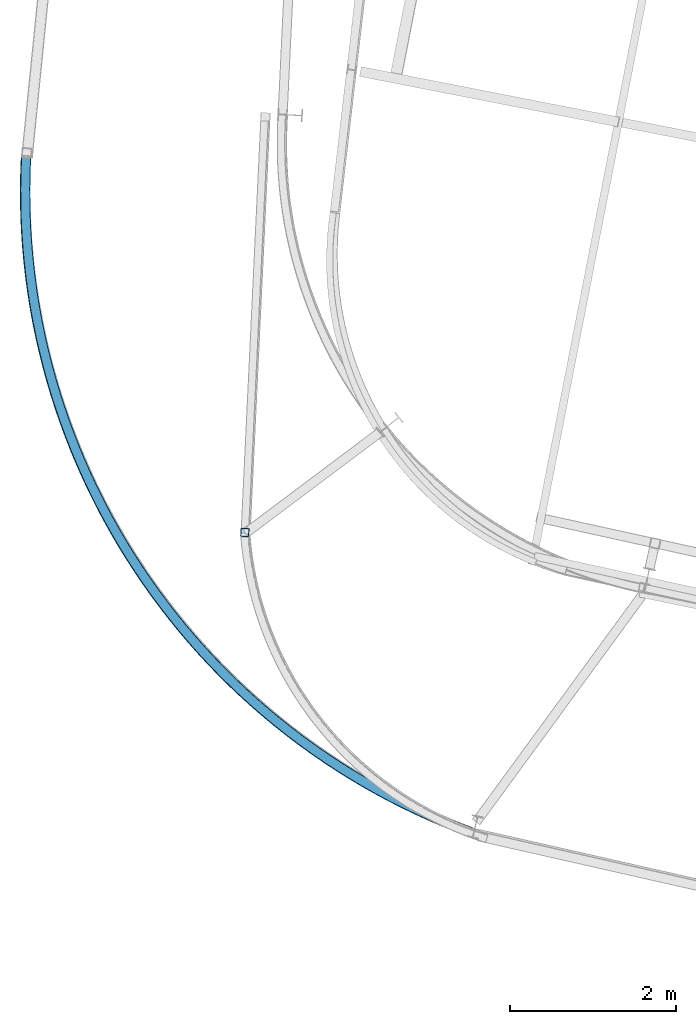
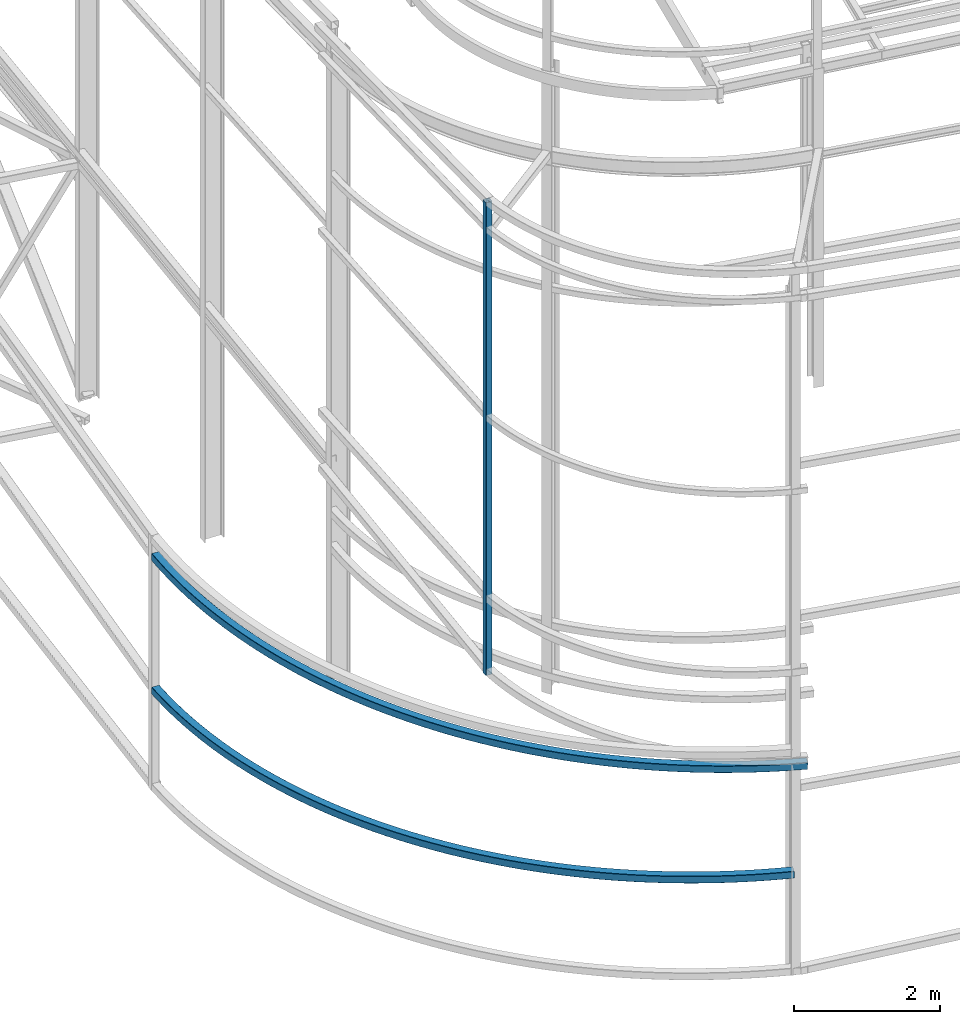
# One storey, part 16 of 215: 3 beams, 3 elements without a shape of their own.
"""IFC2X3 building model written with IfcOpenShell, lengths in millimetres."""

from ifc_helpers import new_model, entity, si_unit, frame, origin_with_axes, origin_2d_with_axis, place, context, subcontext, project, spatial, hollow_rectangle, extrude, material, type_object, element, aggregate, save


model = new_model("IFC2X3")

# Units and contexts
model_context = context("Model", 3, precision=1e-05, world=origin_with_axes())
body_context = subcontext(model_context, "Body", "Model", "MODEL_VIEW")
ifc_project = project(units=[si_unit("LENGTHUNIT", "METRE", prefix="MILLI"), si_unit("AREAUNIT", "SQUARE_METRE"), si_unit("VOLUMEUNIT", "CUBIC_METRE"), si_unit("MASSUNIT", "GRAM", prefix="KILO"), si_unit("TIMEUNIT", "SECOND"), si_unit("PLANEANGLEUNIT", "RADIAN"), si_unit("SOLIDANGLEUNIT", "STERADIAN"), si_unit("THERMODYNAMICTEMPERATUREUNIT", "DEGREE_CELSIUS"), si_unit("LUMINOUSINTENSITYUNIT", "LUMEN")], contexts=[model_context])

# Site, building, storey
site_placement = place(None, origin_with_axes())
site = spatial("IfcSite", under=ifc_project, at=site_placement, CompositionType="ELEMENT")
building_placement = place(site_placement, origin_with_axes())
building = spatial("IfcBuilding", under=site, at=building_placement, Name="Undefined", CompositionType="ELEMENT")
storey_placement = place(building_placement, origin_with_axes())
storey = spatial("IfcBuildingStorey", under=building, at=storey_placement, Name="Undefined", CompositionType="ELEMENT", Elevation=0.0)

# Assembly, beam
assembly_1_placement = place(storey_placement, origin_with_axes())
assembly_1 = element("IfcElementAssembly", 1, at=assembly_1_placement, inside=storey, Name="Steel Assembly", AssemblyPlace="NOTDEFINED", PredefinedType="RIGID_FRAME")
ifc_material = material(Name="STEEL/S275JR")
beam_type_1 = type_object("IfcBeamType", PredefinedType="NOTDEFINED")
beam_1_placement = place(assembly_1_placement, frame((39533.688851777, 7898.74058350471, 1226.42980012292), z_axis=(0.0, 0.0, 1.0), x_axis=(-0.551321645970152, 0.834292779954832, 0.0)))
beam_1 = element("IfcBeam", 2, at=beam_1_placement, type_object=beam_type_1, material=ifc_material, Name="LISSE", context=body_context, shape_type="SweptSolid", body=[
    entity("IfcRevolvedAreaSolid", entity("IfcRectangleHollowProfileDef", "AREA", None, entity("IfcAxis2Placement2D", entity("IfcCartesianPoint", [0.0, 0.0]), entity("IfcDirection", [1.0, 0.0])), 120.0, 120.0, 5.0, 5.0, 10.0), entity("IfcAxis2Placement3D", entity("IfcCartesianPoint", [9767.05736409933, 0.0, 0.0]), entity("IfcDirection", [-0.805451826821809, 0.592661247821561, 0.0]), entity("IfcDirection", [-0.592661247821561, -0.805451826821809, 0.0])), entity("IfcAxis1Placement", entity("IfcCartesianPoint", [8240.0, 0.0, 0.0]), entity("IfcDirection", [0.0, 1.0, 0.0])), 1.26871776721271),
])
aggregate(assembly_1, [beam_1])

assembly_2_placement = place(storey_placement, origin_with_axes())
assembly_2 = element("IfcElementAssembly", 3, at=assembly_2_placement, inside=storey, Name="Steel Assembly", AssemblyPlace="NOTDEFINED", PredefinedType="RIGID_FRAME")
beam_2_placement = place(assembly_2_placement, frame((39708.9148953482, 7837.47559102582, 3023.55441748782), z_axis=(0.0247060010099855, -0.0364801280147465, 0.999028935403836), x_axis=(-0.56020491912133, 0.827181517179151, 0.0440588950095423)))
beam_2 = element("IfcBeam", 4, at=beam_2_placement, type_object=beam_type_1, material=ifc_material, Name="LISSE", context=body_context, shape_type="SweptSolid", body=[
    entity("IfcRevolvedAreaSolid", entity("IfcRectangleHollowProfileDef", "AREA", None, entity("IfcAxis2Placement2D", entity("IfcCartesianPoint", [0.0, 0.0]), entity("IfcDirection", [1.0, 0.0])), 120.0, 120.0, 5.0, 5.0, 10.0), entity("IfcAxis2Placement3D", entity("IfcCartesianPoint", [9927.63593396693, 6.94386312376568e-12, 5.23634163348878e-13]), entity("IfcDirection", [-0.798190518504606, 0.602405093080518, -8.44166907686276e-18]), entity("IfcDirection", [-0.602405093080518, -0.798190518504606, -3.33386434989841e-19])), entity("IfcAxis1Placement", entity("IfcCartesianPoint", [8240.0, 0.0, 0.0]), entity("IfcDirection", [0.0, 1.0, 0.0])), 1.29302175339806),
])
aggregate(assembly_2, [beam_2])

assembly_3_placement = place(storey_placement, origin_with_axes())
assembly_3 = element("IfcElementAssembly", 5, at=assembly_3_placement, inside=storey, Name="Steel Assembly", AssemblyPlace="NOTDEFINED", PredefinedType="RIGID_FRAME")
beam_type_2 = type_object("IfcBeamType", PredefinedType="NOTDEFINED")
beam_3_placement = place(assembly_3_placement, frame((36788.3807535515, 11524.7854740586, 11226.829714199), z_axis=(0.998866412658517, -0.0476013619837276, 0.0), x_axis=(0.0, 0.0, -1.0)))
beam_3 = element("IfcBeam", 6, at=beam_3_placement, type_object=beam_type_2, material=ifc_material, Name="MONTANT", context=body_context, shape_type="SweptSolid", body=[
    extrude(hollow_rectangle(XDim=100.0, YDim=100.0, WallThickness=5.0, InnerFilletRadius=5.0, OuterFilletRadius=10.0, at=origin_2d_with_axis()), frame((7904.79719734173, -1.63467374695115e-21, 1.63467374695115e-21), z_axis=(-1.0, 0.0, 0.0), x_axis=(-6.93889390390723e-18, -1.0, -3.46944695195361e-18)), (0.0, 0.0, 1.0), 7904.8),
])
aggregate(assembly_3, [beam_3])

save(model, "model.ifc")
